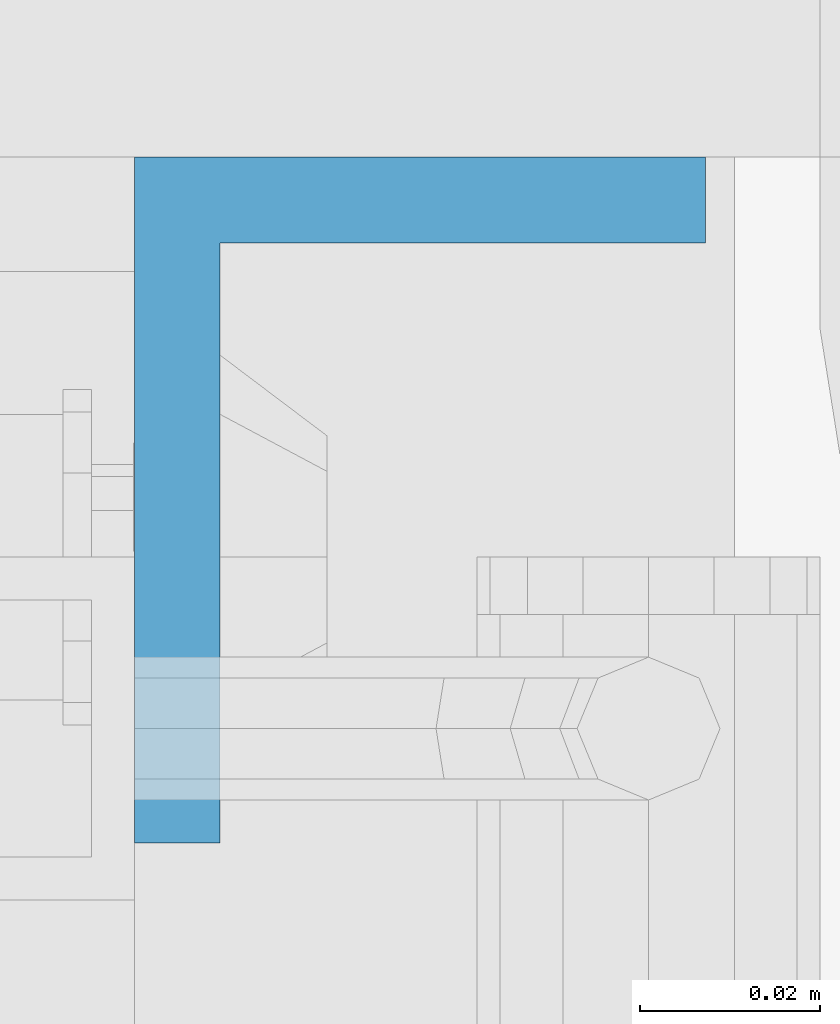
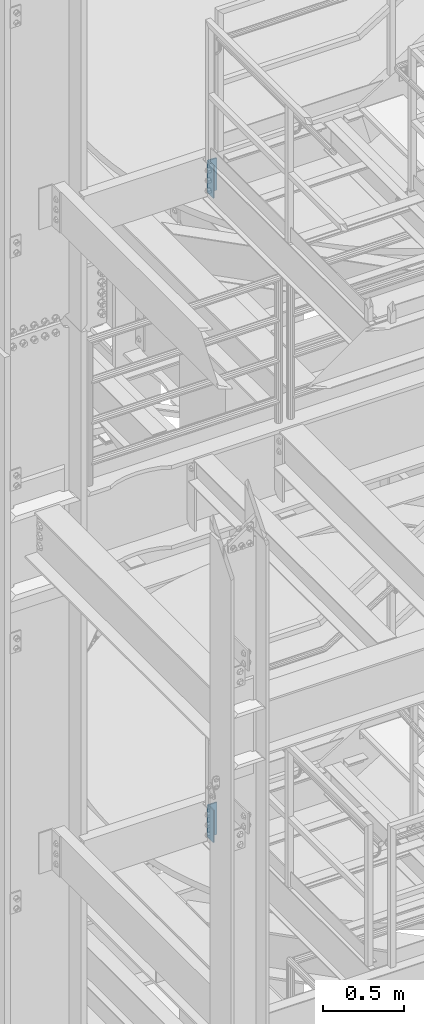
# One storey, part 818 of 1876: 2 columns, 2 elements without a shape of their own.
"""IFC2X3 building model written with IfcOpenShell, lengths in millimetres."""

from ifc_helpers import new_model, si_unit, frame, origin_with_axes, place, context, subcontext, project, spatial, faceted_brep, material, type_object, element, aggregate, save


model = new_model("IFC2X3")

# Units and contexts
model_context = context("Model", 3, precision=1e-05, world=origin_with_axes())
body_context = subcontext(model_context, "Body", "Model", "MODEL_VIEW")
ifc_project = project(units=[si_unit("LENGTHUNIT", "METRE", prefix="MILLI"), si_unit("AREAUNIT", "SQUARE_METRE"), si_unit("VOLUMEUNIT", "CUBIC_METRE"), si_unit("MASSUNIT", "GRAM", prefix="KILO"), si_unit("TIMEUNIT", "SECOND"), si_unit("PLANEANGLEUNIT", "RADIAN"), si_unit("SOLIDANGLEUNIT", "STERADIAN"), si_unit("THERMODYNAMICTEMPERATUREUNIT", "DEGREE_CELSIUS"), si_unit("LUMINOUSINTENSITYUNIT", "LUMEN")], contexts=[model_context])

# Site, building, storey
site_placement = place(None, origin_with_axes())
site = spatial("IfcSite", under=ifc_project, at=site_placement, CompositionType="ELEMENT")
building_placement = place(site_placement, origin_with_axes())
building = spatial("IfcBuilding", under=site, at=building_placement, Name="Undefined", CompositionType="ELEMENT")
storey_placement = place(building_placement, origin_with_axes())
storey = spatial("IfcBuildingStorey", under=building, at=storey_placement, Name="Undefined", CompositionType="ELEMENT", Elevation=0.0)

# Assembly, column
assembly_1_placement = place(storey_placement, origin_with_axes())
assembly_1 = element("IfcElementAssembly", 1, at=assembly_1_placement, inside=storey, Name="STRINGER", AssemblyPlace="NOTDEFINED", PredefinedType="RIGID_FRAME")
ifc_material = material(Name="STEEL/A36")
column_type = type_object("IfcColumnType", Name="L3X2-1/2X3/8", PredefinedType="NOTDEFINED")
column_1_placement = place(assembly_1_placement, frame((1136.65000038237, -4838.7000011052, 15320.962499997), z_axis=(0.0, -1.0, 0.0), x_axis=(0.0, 0.0, 1.0)))
column_1 = element("IfcColumn", 2, at=column_1_placement, type_object=column_type, material=ifc_material, Name="ANGLE", ObjectType="L3X2-1/2X3/8", context=body_context, shape_type="Brep", body=[
    faceted_brep([(0.0, 31.75, -38.1000000000004), (0.0, 31.75, 38.1000000000004), (241.299999999999, 31.75, 38.1000000000004), (241.299999999999, 31.75, -38.1000000000004), (0.0, 22.2249999999999, 38.1000000000004), (241.299999999999, 22.2249999999999, 38.1000000000004), (0.0, 22.2249999999999, -28.5749999999998), (241.299999999999, 22.2249999999999, -28.5749999999998), (0.0, -31.75, -28.5749999999998), (241.299999999999, -31.75, -28.5749999999998), (0.0, -31.75, -38.1000000000004), (241.299999999999, -31.75, -38.1000000000004)], [[[0, 1, 2, 3]], [[1, 4, 5, 2]], [[4, 6, 7, 5]], [[6, 8, 9, 7]], [[8, 10, 11, 9]], [[10, 0, 3, 11]], [[5, 7, 9, 11, 3, 2]], [[10, 8, 6, 4, 1, 0]]]),
])
aggregate(assembly_1, [column_1])

assembly_2_placement = place(storey_placement, origin_with_axes())
assembly_2 = element("IfcElementAssembly", 3, at=assembly_2_placement, inside=storey, Name="STRINGER", AssemblyPlace="NOTDEFINED", PredefinedType="RIGID_FRAME")
column_2_placement = place(assembly_2_placement, frame((1136.65000038237, -4838.7000011052, 10493.374999997), z_axis=(0.0, -1.0, 0.0), x_axis=(0.0, 0.0, 1.0)))
column_2 = element("IfcColumn", 4, at=column_2_placement, type_object=column_type, material=ifc_material, Name="ANGLE", ObjectType="L3X2-1/2X3/8", context=body_context, shape_type="Brep", body=[
    faceted_brep([(0.0, 31.75, -38.1000000000004), (0.0, 31.75, 38.1000000000004), (241.299999999999, 31.75, 38.1000000000004), (241.299999999999, 31.75, -38.1000000000004), (0.0, 22.2249999999999, 38.1000000000004), (241.299999999999, 22.2249999999999, 38.1000000000004), (0.0, 22.2249999999999, -28.5749999999998), (241.299999999999, 22.2249999999999, -28.5749999999998), (0.0, -31.75, -28.5749999999998), (241.299999999999, -31.75, -28.5749999999998), (0.0, -31.75, -38.1000000000004), (241.299999999999, -31.75, -38.1000000000004)], [[[0, 1, 2, 3]], [[1, 4, 5, 2]], [[4, 6, 7, 5]], [[6, 8, 9, 7]], [[8, 10, 11, 9]], [[10, 0, 3, 11]], [[5, 7, 9, 11, 3, 2]], [[10, 8, 6, 4, 1, 0]]]),
])
aggregate(assembly_2, [column_2])

save(model, "model.ifc")
